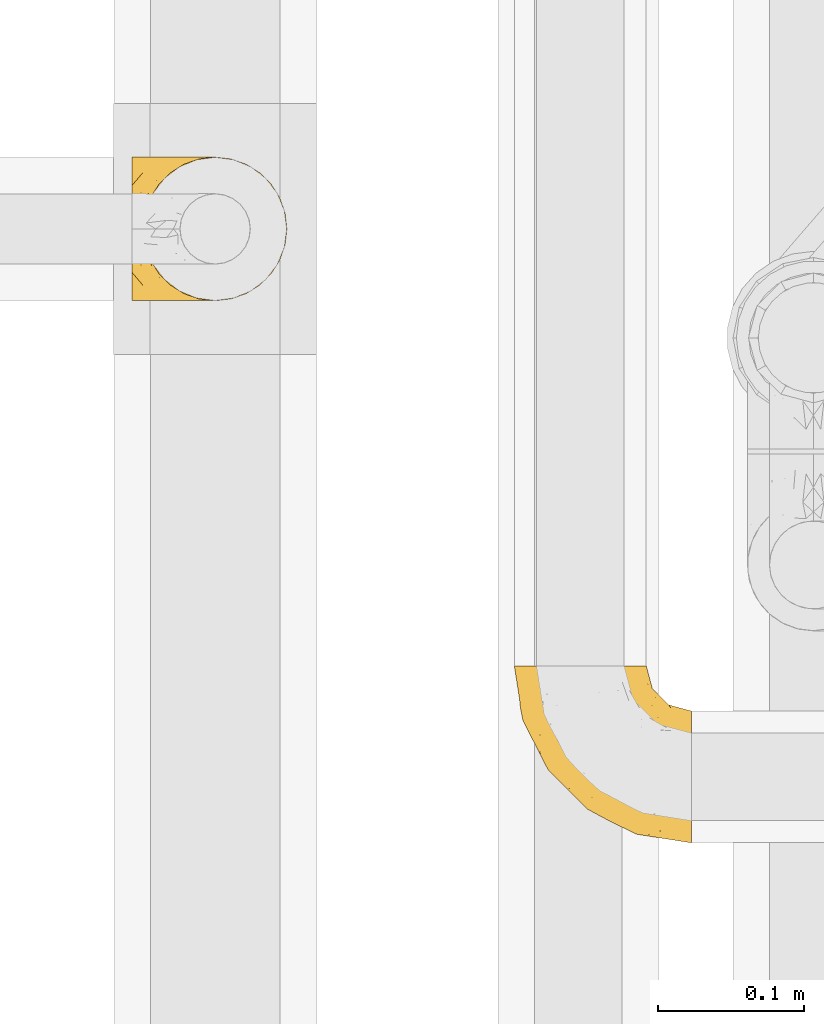
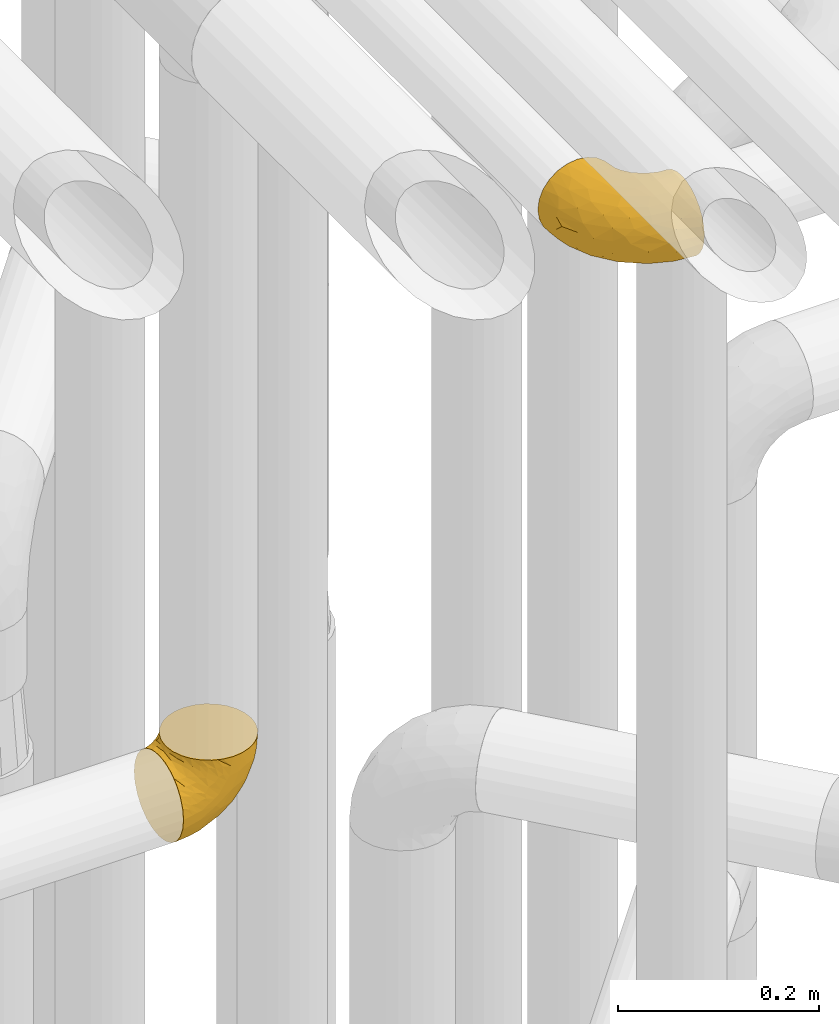
# One storey, part 192 of 827: 2 coverings.
"""IFC2X3 building model written with IfcOpenShell, lengths in millimetres."""

from ifc_helpers import new_model, entity, si_unit, converted_unit, derived_unit, direction, frame, origin, place, context, subcontext, project, spatial, faceted_brep, element, save


model = new_model("IFC2X3")

# Units and contexts
model_context = context("Model", 3, precision=0.01, world=origin(), true_north=direction((6.12303176911189e-17, 1.0)))
body_context = subcontext(model_context, "Body", "Model", "MODEL_VIEW")
ifc_project = project(units=[si_unit("LENGTHUNIT", "METRE", prefix="MILLI"), si_unit("AREAUNIT", "SQUARE_METRE"), si_unit("VOLUMEUNIT", "CUBIC_METRE"), converted_unit("PLANEANGLEUNIT", "DEGREE", entity("IfcRatioMeasure", 0.0174532925199433), si_unit("PLANEANGLEUNIT", "RADIAN"), dimensions=[0, 0, 0, 0, 0, 0, 0]), si_unit("MASSUNIT", "GRAM", prefix="KILO"), derived_unit("MASSDENSITYUNIT", [(si_unit("MASSUNIT", "GRAM", prefix="KILO"), 1), (si_unit("LENGTHUNIT", "METRE"), -3)]), derived_unit("MOMENTOFINERTIAUNIT", [(si_unit("LENGTHUNIT", "METRE"), 4)]), si_unit("TIMEUNIT", "SECOND"), si_unit("FREQUENCYUNIT", "HERTZ"), si_unit("THERMODYNAMICTEMPERATUREUNIT", "DEGREE_CELSIUS"), derived_unit("THERMALTRANSMITTANCEUNIT", [(si_unit("MASSUNIT", "GRAM", prefix="KILO"), 1), (si_unit("THERMODYNAMICTEMPERATUREUNIT", "KELVIN"), -1), (si_unit("TIMEUNIT", "SECOND"), -3)]), derived_unit("VOLUMETRICFLOWRATEUNIT", [(si_unit("LENGTHUNIT", "METRE"), 3), (si_unit("TIMEUNIT", "SECOND"), -1)]), derived_unit("MASSFLOWRATEUNIT", [(si_unit("MASSUNIT", "GRAM", prefix="KILO"), 1), (si_unit("TIMEUNIT", "SECOND"), -1)]), derived_unit("ROTATIONALFREQUENCYUNIT", [(si_unit("TIMEUNIT", "SECOND"), -1)]), si_unit("ELECTRICCURRENTUNIT", "AMPERE"), si_unit("ELECTRICVOLTAGEUNIT", "VOLT"), si_unit("POWERUNIT", "WATT"), si_unit("FORCEUNIT", "NEWTON", prefix="KILO"), si_unit("ILLUMINANCEUNIT", "LUX"), si_unit("LUMINOUSFLUXUNIT", "LUMEN"), si_unit("LUMINOUSINTENSITYUNIT", "CANDELA"), derived_unit("USERDEFINED", [(si_unit("MASSUNIT", "GRAM", prefix="KILO"), -1), (si_unit("LENGTHUNIT", "METRE"), -2), (si_unit("TIMEUNIT", "SECOND"), 3), (si_unit("LUMINOUSFLUXUNIT", "LUMEN"), 1)]), derived_unit("LINEARVELOCITYUNIT", [(si_unit("LENGTHUNIT", "METRE"), 1), (si_unit("TIMEUNIT", "SECOND"), -1)]), si_unit("PRESSUREUNIT", "PASCAL"), derived_unit("USERDEFINED", [(si_unit("LENGTHUNIT", "METRE"), -2), (si_unit("MASSUNIT", "GRAM", prefix="KILO"), 1), (si_unit("TIMEUNIT", "SECOND"), -2)]), derived_unit("LINEARFORCEUNIT", [(si_unit("MASSUNIT", "GRAM", prefix="KILO"), 1), (si_unit("LENGTHUNIT", "METRE"), 1), (si_unit("TIMEUNIT", "SECOND"), -2), (si_unit("LENGTHUNIT", "METRE"), -1)]), derived_unit("PLANARFORCEUNIT", [(si_unit("MASSUNIT", "GRAM", prefix="KILO"), 1), (si_unit("LENGTHUNIT", "METRE"), 1), (si_unit("TIMEUNIT", "SECOND"), -2), (si_unit("LENGTHUNIT", "METRE"), -2)])], contexts=[model_context])

# Site, building, storey
site_placement = place(None, origin())
site = spatial("IfcSite", under=ifc_project, at=site_placement, CompositionType="ELEMENT")
building_placement = place(site_placement, origin())
building = spatial("IfcBuilding", under=site, at=building_placement, CompositionType="ELEMENT")
storey_placement = place(building_placement, frame((0.0, 0.0, 28200.0)))
storey = spatial("IfcBuildingStorey", under=building, at=storey_placement, Name="08", CompositionType="ELEMENT", Elevation=28200.0)

# Coverings
covering_1_placement = place(storey_placement, frame((36161.44, 10105.46, 2549.25)))
element("IfcCovering", 1, at=covering_1_placement, inside=storey, Name=":ADSK_", ObjectType=":ADSK_", PredefinedType="INSULATION", context=body_context, shape_type="Brep", body=[
    faceted_brep([(58.6, 1.6, 107.75), (69.54, 2.83, 107.75), (79.93, 6.47, 107.75), (89.25, 12.32, 107.75), (97.03, 20.11, 107.75), (102.88, 29.43, 107.75), (106.51, 39.81, 107.75), (107.75, 50.75, 107.75), (106.51, 61.69, 107.75), (102.87, 72.08, 107.75), (97.02, 81.4, 107.75), (89.23, 89.18, 107.75), (79.91, 95.03, 107.75), (69.53, 98.66, 107.75), (58.6, 99.9, 107.75), (52.89, 99.25, 107.75), (47.65, 98.66, 107.75), (42.46, 96.84, 107.75), (37.26, 95.02, 107.75), (27.94, 89.17, 107.75), (20.16, 81.38, 107.75), (14.31, 72.06, 107.75), (10.68, 61.68, 107.75), (9.45, 50.75, 107.75), (10.68, 39.8, 107.75), (14.32, 29.41, 107.75), (20.17, 20.09, 107.75), (27.96, 12.31, 107.75), (37.28, 6.46, 107.75), (42.47, 4.64, 107.75), (47.66, 2.83, 107.75), (52.89, 2.24, 107.75), (55.75, 1.92, 107.75), (1.6, 63.47, 98.22), (1.6, 75.32, 93.31), (1.6, 80.41, 89.4), (1.6, 85.5, 85.5), (1.6, 89.4, 80.41), (1.6, 93.31, 75.32), (1.6, 95.77, 69.39), (1.6, 98.22, 63.47), (1.6, 99.14, 56.48), (1.6, 99.52, 53.61), (1.6, 99.9, 50.75), (1.6, 98.22, 38.02), (1.6, 93.31, 26.17), (1.6, 85.5, 15.99), (1.6, 75.32, 8.18), (1.6, 63.47, 3.27), (1.6, 50.75, 1.6), (1.6, 38.02, 3.27), (1.6, 26.17, 8.18), (1.6, 15.99, 15.99), (1.6, 8.18, 26.17), (1.6, 3.27, 38.02), (1.6, 1.6, 50.75), (1.6, 2.35, 56.48), (1.6, 3.27, 63.47), (1.6, 5.73, 69.39), (1.6, 8.18, 75.32), (1.6, 12.09, 80.41), (1.6, 15.99, 85.5), (1.6, 21.08, 89.4), (1.6, 26.17, 93.31), (1.6, 38.02, 98.22), (1.6, 50.75, 99.9), (69.96, 42.18, 27.53), (59.59, 28.42, 25.32), (51.96, 37.78, 16.29), (34.4, 50.75, 6.79), (23.37, 42.85, 4.51), (13.68, 50.75, 3.51), (41.52, 24.75, 17.47), (26.26, 33.81, 7.6), (20.18, 22.57, 12.27), (72.33, 7.18, 70.89), (65.88, 2.73, 87.17), (57.55, 3.09, 67.3), (23.76, 6.92, 31.65), (46.5, 11.58, 33.58), (46.57, 5.17, 47.23), (21.17, 2.71, 43.26), (23.41, 1.6, 55.08), (17.92, 1.6, 53.99), (12.43, 1.6, 52.9), (9.72, 1.6, 52.36), (7.01, 1.6, 51.82), (26.77, 14.18, 21.5), (76.59, 5.88, 89.94), (95.55, 41.06, 60.45), (102.57, 36.25, 83.0), (92.89, 28.62, 64.79), (54.26, 1.6, 85.93), (51.17, 1.6, 81.31), (48.08, 1.6, 76.69), (44.99, 1.6, 72.06), (41.9, 1.6, 67.44), (85.16, 10.85, 88.74), (85.97, 38.35, 45.98), (59.58, 9.6, 47.13), (99.5, 26.24, 89.4), (105.83, 50.75, 95.66), (53.59, 19.31, 28.5), (67.0, 16.41, 42.81), (71.56, 24.56, 38.28), (87.47, 50.75, 45.35), (75.73, 50.75, 33.61), (92.24, 18.47, 82.57), (58.06, 1.6, 105.04), (57.52, 1.6, 102.33), (56.44, 1.6, 96.91), (55.35, 1.6, 91.42), (81.33, 14.36, 65.92), (80.35, 20.64, 53.11), (39.44, 2.32, 54.37), (102.55, 50.75, 74.94), (37.28, 1.6, 64.35), (32.65, 1.6, 61.26), (28.03, 1.6, 58.17), (63.99, 50.75, 21.87), (74.55, 33.88, 34.79), (83.62, 29.24, 48.48), (95.01, 50.75, 60.15), (49.19, 50.75, 14.33), (46.96, 2.8, 99.07), (8.77, 2.48, 60.55), (18.28, 2.7, 64.18), (11.68, 3.2, 64.36), (11.79, 32.98, 103.17), (15.69, 24.67, 101.69), (42.49, 2.95, 87.75), (47.41, 2.19, 89.38), (7.94, 17.92, 88.34), (9.27, 12.02, 82.14), (7.98, 25.73, 94.51), (13.4, 16.63, 89.64), (13.04, 25.6, 98.41), (7.36, 36.72, 99.71), (23.46, 10.66, 89.37), (30.46, 6.87, 88.21), (26.54, 11.12, 95.2), (6.76, 10.31, 79.14), (26.46, 12.84, 101.22), (20.77, 17.38, 99.41), (20.68, 9.74, 84.72), (40.26, 4.63, 97.47), (7.15, 50.75, 102.19), (9.28, 42.52, 104.02), (38.78, 3.12, 82.66), (18.27, 17.58, 95.42), (31.78, 3.97, 78.67), (12.75, 5.94, 72.69), (22.96, 2.73, 66.46), (17.55, 6.23, 75.3), (27.63, 3.45, 72.74), (15.23, 10.84, 82.93), (33.25, 7.98, 99.27), (32.43, 7.33, 93.51), (27.9, 2.39, 67.35), (7.97, 75.76, 94.51), (15.22, 90.65, 82.94), (7.93, 83.57, 88.33), (13.38, 84.85, 89.64), (13.12, 71.05, 103.62), (42.49, 98.54, 87.74), (47.4, 99.3, 89.38), (51.17, 99.9, 81.31), (40.24, 96.86, 97.47), (20.76, 84.1, 99.41), (12.43, 99.9, 52.9), (7.01, 99.9, 51.82), (4.31, 99.9, 51.28), (26.44, 88.63, 101.21), (26.52, 90.36, 95.19), (11.68, 98.29, 64.36), (12.75, 95.55, 72.69), (9.27, 89.47, 82.13), (17.55, 95.26, 75.3), (6.76, 91.18, 79.14), (33.21, 93.49, 99.28), (32.41, 94.15, 93.51), (8.77, 99.01, 60.55), (22.96, 98.76, 66.46), (18.48, 98.85, 63.96), (56.44, 99.9, 96.91), (46.95, 98.69, 99.06), (7.36, 64.78, 99.7), (17.92, 99.9, 53.99), (23.41, 99.9, 55.08), (9.85, 62.91, 103.3), (57.52, 99.9, 102.33), (56.98, 99.9, 99.62), (48.08, 99.9, 76.69), (38.78, 98.37, 82.66), (18.25, 83.9, 95.42), (44.99, 99.9, 72.06), (31.74, 97.51, 78.68), (30.45, 94.62, 88.2), (27.63, 98.04, 72.75), (20.65, 91.73, 84.74), (55.35, 99.9, 91.42), (54.26, 99.9, 85.93), (13.03, 75.87, 98.41), (23.44, 90.83, 89.37), (27.9, 99.1, 67.35), (32.65, 99.9, 61.26), (28.03, 99.9, 58.17), (37.28, 99.9, 64.35), (41.9, 99.9, 67.44), (39.74, 99.09, 54.08), (23.37, 58.64, 4.51), (26.77, 87.31, 21.5), (46.18, 89.93, 33.43), (53.54, 82.22, 28.5), (41.53, 76.74, 17.47), (59.61, 73.12, 25.36), (76.79, 95.54, 90.18), (66.11, 98.7, 86.97), (21.17, 98.79, 43.26), (51.96, 63.71, 16.29), (26.26, 67.68, 7.6), (20.18, 78.92, 12.27), (23.76, 94.57, 31.65), (92.88, 72.88, 64.79), (102.57, 65.25, 83.0), (95.54, 60.44, 60.44), (71.63, 76.94, 38.35), (74.55, 67.61, 34.8), (72.51, 94.38, 71.54), (69.96, 59.31, 27.53), (92.23, 83.03, 82.57), (85.15, 90.66, 88.74), (80.45, 80.8, 53.19), (83.65, 72.22, 48.49), (57.57, 98.39, 67.28), (63.68, 92.31, 52.32), (85.95, 63.11, 45.94), (99.49, 75.27, 89.4), (81.23, 87.15, 65.75), (47.07, 96.03, 46.73), (66.99, 85.1, 42.82)], [[[0, 1, 2, 3, 4, 5, 6, 7, 8, 9, 10, 11, 12, 13, 14, 15, 16, 17, 18, 19, 20, 21, 22, 23, 24, 25, 26, 27, 28, 29, 30, 31, 32]], [[33, 34, 35, 36, 37, 38, 39, 40, 41, 42, 43, 44, 45, 46, 47, 48, 49, 50, 51, 52, 53, 54, 55, 56, 57, 58, 59, 60, 61, 62, 63, 64, 65]], [[66, 67, 68]], [[69, 70, 71]], [[68, 72, 73]], [[73, 72, 74]], [[75, 76, 77]], [[78, 79, 80]], [[51, 50, 73]], [[81, 82, 83, 84, 85, 86, 55]], [[52, 87, 53]], [[74, 52, 51]], [[2, 1, 88]], [[89, 90, 91]], [[77, 92, 93, 94, 95, 96]], [[55, 54, 81]], [[78, 53, 87]], [[5, 90, 6]], [[88, 76, 75]], [[97, 3, 2]], [[89, 91, 98]], [[99, 80, 79]], [[90, 5, 100]], [[74, 87, 52]], [[100, 5, 4]], [[90, 101, 6]], [[79, 102, 103]], [[102, 67, 104]], [[105, 98, 106]], [[107, 4, 3]], [[76, 0, 108, 109, 110, 111, 92]], [[107, 112, 113]], [[114, 77, 96]], [[89, 115, 90]], [[114, 96, 116, 117, 118, 82]], [[75, 97, 88]], [[119, 66, 68]], [[50, 71, 70]], [[100, 91, 90]], [[99, 77, 80]], [[102, 104, 103]], [[97, 107, 3]], [[80, 81, 78]], [[107, 97, 112]], [[68, 73, 70]], [[66, 98, 120]], [[78, 81, 54]], [[114, 81, 80]], [[53, 78, 54]], [[78, 87, 79]], [[102, 87, 72]], [[79, 103, 99]], [[4, 107, 100]], [[91, 100, 107]], [[88, 97, 2]], [[112, 97, 75]], [[99, 112, 75]], [[103, 104, 113]], [[91, 121, 98]], [[89, 105, 122, 115]], [[101, 90, 115]], [[101, 7, 6]], [[88, 1, 76]], [[0, 76, 1]], [[92, 77, 76]], [[73, 74, 51]], [[87, 74, 72]], [[81, 114, 82]], [[77, 114, 80]], [[87, 102, 79]], [[67, 102, 72]], [[68, 67, 72]], [[67, 120, 104]], [[120, 121, 104]], [[104, 121, 113]], [[121, 120, 98]], [[91, 107, 113]], [[91, 113, 121]], [[103, 113, 112]], [[106, 98, 66]], [[105, 89, 98]], [[106, 66, 119]], [[67, 66, 120]], [[68, 69, 123, 119]], [[50, 49, 71]], [[50, 70, 73]], [[112, 99, 103]], [[77, 99, 75]], [[69, 68, 70]], [[29, 124, 110]], [[84, 83, 125]], [[126, 82, 118]], [[59, 58, 127]], [[25, 128, 129]], [[130, 93, 131]], [[132, 62, 133]], [[134, 135, 136]], [[137, 65, 64]], [[64, 134, 137]], [[138, 139, 140]], [[111, 110, 124, 92]], [[134, 136, 137]], [[134, 64, 63]], [[141, 61, 60]], [[125, 58, 57]], [[142, 143, 140]], [[142, 26, 143]], [[127, 83, 82]], [[28, 124, 29]], [[108, 0, 32, 31, 30, 110, 109]], [[30, 29, 110]], [[135, 144, 138]], [[28, 145, 124]], [[57, 56, 55, 86, 85, 84]], [[146, 147, 23]], [[24, 23, 147]], [[25, 143, 26]], [[95, 94, 148]], [[24, 128, 25]], [[149, 138, 143]], [[124, 145, 131]], [[127, 58, 125]], [[150, 148, 139]], [[127, 126, 151]], [[151, 59, 127]], [[152, 151, 126]], [[153, 154, 155]], [[153, 133, 141]], [[145, 28, 27]], [[142, 156, 27]], [[157, 148, 130]], [[61, 133, 62]], [[134, 132, 135]], [[147, 128, 24]], [[65, 137, 146]], [[146, 137, 147]], [[128, 137, 136]], [[137, 128, 147]], [[128, 136, 129]], [[149, 129, 136]], [[25, 129, 143]], [[158, 152, 117]], [[152, 118, 117]], [[153, 151, 152]], [[158, 116, 154]], [[144, 150, 138]], [[153, 152, 158]], [[133, 153, 155]], [[133, 155, 132]], [[60, 151, 141]], [[135, 132, 155]], [[134, 63, 132]], [[144, 135, 155]], [[135, 138, 149]], [[155, 154, 144]], [[150, 154, 96]], [[154, 150, 144]], [[148, 94, 130]], [[82, 126, 127]], [[118, 152, 126]], [[150, 96, 95]], [[139, 148, 157]], [[150, 95, 148]], [[93, 92, 131]], [[130, 145, 156]], [[130, 94, 93]], [[84, 125, 57]], [[127, 125, 83]], [[140, 139, 157]], [[150, 139, 138]], [[140, 157, 142]], [[138, 140, 143]], [[156, 142, 157]], [[27, 26, 142]], [[130, 156, 157]], [[145, 27, 156]], [[132, 63, 62]], [[124, 131, 92]], [[130, 131, 145]], [[129, 149, 143]], [[135, 149, 136]], [[141, 133, 61]], [[60, 59, 151]], [[141, 151, 153]], [[116, 96, 154]], [[153, 158, 154]], [[158, 117, 116]], [[34, 33, 159]], [[160, 161, 162]], [[22, 21, 163]], [[164, 165, 166]], [[19, 18, 167]], [[168, 21, 20]], [[42, 41, 40, 169, 170, 171, 43]], [[172, 173, 168]], [[174, 38, 175]], [[176, 177, 178]], [[179, 164, 180]], [[40, 181, 169]], [[182, 183, 175]], [[17, 184, 185]], [[65, 146, 186]], [[187, 174, 188]], [[23, 22, 189]], [[174, 39, 38]], [[15, 14, 190, 191, 184, 16]], [[181, 40, 39]], [[192, 193, 164]], [[194, 163, 168]], [[33, 186, 159]], [[180, 173, 172]], [[195, 196, 193]], [[18, 185, 167]], [[173, 180, 197]], [[198, 199, 196]], [[200, 201, 185, 184]], [[184, 17, 16]], [[18, 17, 185]], [[202, 159, 186]], [[194, 168, 203]], [[189, 163, 202]], [[204, 205, 182]], [[187, 181, 174]], [[160, 177, 176]], [[206, 183, 182]], [[206, 182, 205]], [[201, 165, 185]], [[165, 164, 167]], [[172, 179, 180]], [[202, 194, 162]], [[176, 161, 160]], [[65, 186, 33]], [[163, 189, 22]], [[175, 177, 182]], [[174, 183, 188]], [[177, 198, 204]], [[199, 160, 162]], [[198, 207, 204]], [[175, 38, 37]], [[198, 177, 160]], [[178, 177, 175]], [[176, 35, 161]], [[34, 159, 161]], [[162, 161, 159]], [[202, 162, 159]], [[199, 162, 203]], [[196, 199, 203]], [[198, 160, 199]], [[193, 197, 180]], [[208, 198, 196]], [[188, 183, 206]], [[175, 183, 174]], [[193, 192, 195]], [[195, 208, 196]], [[197, 196, 203]], [[180, 164, 193]], [[168, 163, 21]], [[166, 165, 201]], [[166, 192, 164]], [[189, 202, 186]], [[186, 146, 189]], [[23, 189, 146]], [[174, 181, 39]], [[169, 181, 187]], [[196, 197, 193]], [[173, 203, 168]], [[203, 173, 197]], [[172, 168, 20]], [[20, 19, 172]], [[179, 172, 19]], [[19, 167, 179]], [[164, 179, 167]], [[35, 176, 36]], [[35, 34, 161]], [[185, 165, 167]], [[162, 194, 203]], [[163, 194, 202]], [[176, 178, 36]], [[37, 36, 178]], [[175, 37, 178]], [[177, 204, 182]], [[207, 198, 208]], [[207, 205, 204]], [[209, 188, 206, 205, 207, 208]], [[48, 210, 71]], [[211, 212, 213]], [[214, 213, 215]], [[216, 217, 13]], [[218, 43, 171, 170, 169, 187, 188]], [[219, 220, 214]], [[47, 46, 221]], [[210, 48, 220]], [[211, 222, 212]], [[222, 45, 44]], [[221, 220, 47]], [[47, 220, 48]], [[221, 211, 214]], [[223, 224, 225]], [[211, 46, 45]], [[226, 227, 215]], [[43, 218, 44]], [[217, 216, 228]], [[219, 215, 229]], [[14, 13, 217]], [[224, 9, 8]], [[10, 230, 11]], [[11, 231, 12]], [[232, 223, 233]], [[234, 208, 195, 192, 166, 201]], [[235, 234, 228]], [[222, 44, 218]], [[106, 229, 236]], [[224, 237, 9]], [[231, 238, 228]], [[9, 237, 10]], [[115, 224, 101]], [[239, 234, 235]], [[231, 11, 230]], [[223, 230, 237]], [[224, 8, 101]], [[223, 236, 233]], [[225, 115, 122, 105]], [[216, 12, 231]], [[209, 234, 239]], [[210, 219, 69]], [[219, 214, 215]], [[229, 119, 219]], [[209, 218, 188]], [[239, 212, 222]], [[239, 222, 218]], [[45, 222, 211]], [[235, 212, 239]], [[213, 212, 240]], [[223, 237, 224]], [[230, 10, 237]], [[238, 231, 230]], [[216, 231, 228]], [[232, 230, 223]], [[235, 238, 240]], [[115, 225, 224]], [[233, 236, 227]], [[8, 7, 101]], [[234, 209, 208]], [[218, 209, 239]], [[217, 228, 234]], [[13, 12, 216]], [[234, 201, 217]], [[217, 201, 200, 184, 191, 190, 14]], [[211, 221, 46]], [[220, 221, 214]], [[71, 210, 69]], [[71, 49, 48]], [[219, 210, 220]], [[226, 215, 213]], [[211, 213, 214]], [[226, 213, 240]], [[215, 227, 229]], [[232, 240, 238]], [[233, 227, 226]], [[232, 233, 226]], [[236, 223, 225]], [[240, 232, 226]], [[232, 238, 230]], [[225, 105, 236]], [[236, 105, 106]], [[236, 229, 227]], [[123, 69, 219, 119]], [[106, 119, 229]], [[238, 235, 228]], [[212, 235, 240]]]),
])
covering_2_placement = place(storey_placement, frame((36423.29, 9734.28, 3353.25)))
element("IfcCovering", 2, at=covering_2_placement, inside=storey, Name=":ADSK_", ObjectType=":ADSK_", PredefinedType="INSULATION", context=body_context, shape_type="Brep", body=[
    faceted_brep([(122.75, 36.69, 90.76), (122.75, 27.15, 87.42), (122.75, 18.59, 82.04), (122.75, 11.44, 74.89), (122.75, 6.06, 66.33), (122.75, 2.73, 56.79), (122.75, 1.6, 46.75), (122.75, 2.73, 36.69), (122.75, 6.07, 27.15), (122.75, 11.45, 18.59), (122.75, 18.6, 11.44), (122.75, 27.16, 6.06), (122.75, 36.7, 2.73), (122.75, 46.75, 1.6), (122.75, 56.8, 2.73), (122.75, 66.34, 6.07), (122.75, 74.9, 11.45), (122.75, 82.05, 18.6), (122.75, 87.43, 27.16), (122.75, 90.76, 36.7), (122.75, 91.9, 46.75), (122.75, 90.76, 56.8), (122.75, 87.42, 66.34), (122.75, 82.04, 74.9), (122.75, 74.89, 82.05), (122.75, 66.33, 87.43), (122.75, 56.79, 90.76), (122.75, 46.75, 91.9), (90.36, 122.75, 35.06), (85.85, 122.75, 24.17), (78.67, 122.75, 14.82), (69.32, 122.75, 7.64), (58.43, 122.75, 3.13), (46.75, 122.75, 1.6), (35.06, 122.75, 3.13), (24.17, 122.75, 7.64), (14.82, 122.75, 14.82), (7.64, 122.75, 24.17), (3.13, 122.75, 35.06), (1.6, 122.75, 46.75), (3.13, 122.75, 58.43), (7.64, 122.75, 69.32), (14.82, 122.75, 78.67), (24.17, 122.75, 85.85), (35.06, 122.75, 90.36), (46.75, 122.75, 91.9), (58.43, 122.75, 90.36), (69.32, 122.75, 85.85), (78.67, 122.75, 78.67), (85.85, 122.75, 69.32), (90.36, 122.75, 58.43), (91.9, 122.75, 46.75), (51.54, 24.73, 46.75), (47.17, 29.08, 55.2), (38.13, 38.13, 46.75), (7.52, 85.31, 46.75), (5.85, 93.59, 54.53), (5.11, 100.54, 46.75), (19.2, 63.54, 59.63), (38.98, 38.98, 62.07), (35.02, 50.71, 71.86), (8.21, 93.33, 62.65), (19.28, 75.2, 71.33), (12.19, 100.46, 72.93), (101.39, 41.6, 91.2), (34.43, 80.86, 86.31), (20.95, 94.87, 80.89), (30.74, 67.96, 79.49), (72.93, 52.16, 90.68), (56.64, 52.1, 86.84), (80.81, 36.74, 87.38), (93.43, 17.11, 76.87), (100.76, 23.24, 83.73), (74.27, 29.18, 81.03), (93.66, 52.53, 91.9), (81.33, 60.77, 91.9), (69.01, 69.01, 91.9), (40.87, 100.68, 91.03), (29.38, 103.79, 87.58), (67.05, 16.37, 56.52), (85.31, 7.52, 46.75), (93.68, 7.31, 60.4), (52.53, 93.66, 91.9), (50.71, 102.83, 91.9), (48.88, 112.01, 91.9), (72.77, 18.17, 67.87), (51.21, 71.97, 90.35), (101.18, 9.83, 69.57), (100.54, 5.11, 46.75), (48.74, 45.97, 79.91), (112.01, 48.88, 91.9), (102.83, 50.71, 91.9), (73.88, 22.83, 74.99), (24.73, 51.54, 46.75), (60.77, 81.33, 91.9), (103.08, 31.74, 88.53), (54.8, 32.48, 72.65), (16.13, 68.42, 46.75), (55.92, 25.33, 62.97), (68.42, 16.13, 46.75), (104.98, 92.29, 66.2), (108.58, 94.12, 56.6), (98.21, 100.97, 59.89), (61.56, 95.91, 90.95), (60.69, 107.9, 90.22), (100.0, 87.24, 76.64), (95.88, 95.46, 71.58), (90.81, 90.41, 79.99), (84.88, 74.17, 89.54), (73.29, 83.77, 89.97), (113.4, 76.72, 81.32), (109.8, 84.44, 74.56), (102.13, 76.42, 84.15), (67.29, 90.07, 90.37), (70.34, 99.69, 87.82), (95.15, 61.74, 90.98), (105.49, 58.16, 90.96), (71.5, 112.6, 85.14), (92.87, 110.45, 58.11), (96.03, 107.32, 46.75), (81.34, 108.48, 78.39), (107.44, 66.63, 88.22), (88.36, 115.23, 66.06), (90.43, 105.79, 68.6), (114.37, 89.6, 63.78), (98.41, 69.39, 88.42), (88.73, 66.99, 90.61), (76.89, 102.31, 83.8), (86.08, 99.54, 77.98), (112.64, 55.27, 91.22), (94.21, 82.03, 83.46), (112.22, 94.71, 46.75), (107.32, 96.03, 46.75), (79.95, 94.11, 84.66), (84.51, 84.21, 86.33), (101.67, 101.67, 46.75), (94.71, 112.22, 46.75), (81.34, 108.48, 15.1), (76.89, 102.31, 9.69), (86.08, 99.54, 15.52), (79.96, 94.11, 8.83), (92.87, 110.46, 35.39), (113.41, 76.74, 12.18), (102.83, 50.71, 1.6), (105.5, 58.17, 2.53), (112.64, 55.27, 2.27), (108.58, 94.12, 36.9), (104.98, 92.3, 27.31), (98.2, 100.98, 33.62), (98.4, 69.41, 5.07), (102.13, 76.44, 9.36), (107.44, 66.65, 5.27), (88.36, 115.24, 27.43), (50.71, 102.83, 1.6), (48.88, 112.01, 1.6), (94.22, 82.05, 10.05), (100.01, 87.25, 16.87), (71.5, 112.6, 8.35), (60.69, 107.9, 3.27), (52.53, 93.66, 1.6), (95.89, 95.48, 21.94), (114.37, 89.6, 29.72), (81.33, 60.77, 1.6), (69.01, 69.01, 1.6), (84.88, 74.17, 3.96), (112.01, 48.88, 1.6), (109.8, 84.45, 18.95), (61.56, 95.91, 2.54), (67.29, 90.07, 3.12), (60.77, 81.33, 1.6), (95.14, 61.75, 2.51), (73.29, 83.77, 3.52), (84.53, 84.21, 7.17), (93.66, 52.53, 1.6), (90.82, 90.42, 13.52), (88.73, 67.0, 2.88), (70.34, 99.69, 5.67), (90.43, 105.8, 24.89), (20.95, 94.87, 12.6), (34.43, 80.86, 7.18), (30.74, 67.95, 14.0), (19.29, 75.17, 22.16), (35.07, 50.65, 21.61), (51.21, 71.97, 3.14), (56.67, 52.08, 6.65), (54.85, 32.46, 20.82), (38.98, 38.98, 31.41), (29.38, 103.79, 5.91), (40.87, 100.68, 2.46), (19.2, 63.54, 33.87), (8.21, 93.32, 30.84), (5.85, 93.59, 38.96), (12.19, 100.44, 20.56), (72.93, 52.17, 2.81), (80.83, 36.75, 6.1), (101.39, 41.61, 2.29), (93.69, 7.31, 33.08), (93.43, 17.12, 16.61), (67.04, 16.37, 36.96), (100.76, 23.26, 9.75), (72.78, 18.17, 25.61), (55.93, 25.33, 30.5), (101.18, 9.84, 23.91), (74.27, 29.19, 12.45), (73.89, 22.84, 18.49), (103.09, 31.75, 4.96), (48.78, 45.96, 13.56), (47.19, 29.07, 38.28)], [[[0, 1, 2, 3, 4, 5, 6, 7, 8, 9, 10, 11, 12, 13, 14, 15, 16, 17, 18, 19, 20, 21, 22, 23, 24, 25, 26, 27]], [[28, 29, 30, 31, 32, 33, 34, 35, 36, 37, 38, 39, 40, 41, 42, 43, 44, 45, 46, 47, 48, 49, 50, 51]], [[52, 53, 54]], [[55, 56, 57]], [[58, 59, 60]], [[61, 62, 63]], [[27, 64, 0]], [[65, 66, 67]], [[41, 40, 61]], [[68, 69, 70]], [[66, 43, 42]], [[63, 42, 41]], [[71, 72, 73]], [[72, 2, 1]], [[68, 74, 75, 76]], [[45, 44, 77]], [[43, 78, 44]], [[79, 80, 81]], [[77, 82, 83, 84, 45]], [[79, 81, 85]], [[71, 2, 72]], [[65, 86, 77]], [[4, 81, 5]], [[66, 65, 78]], [[4, 3, 87]], [[81, 88, 5]], [[63, 66, 42]], [[68, 70, 64]], [[67, 60, 89]], [[71, 3, 2]], [[64, 27, 90, 91, 74]], [[92, 71, 73]], [[40, 57, 56]], [[59, 93, 54]], [[86, 76, 94, 82]], [[1, 0, 95]], [[58, 62, 61]], [[60, 96, 89]], [[85, 81, 87]], [[56, 97, 58]], [[65, 67, 69]], [[87, 81, 4]], [[67, 89, 69]], [[61, 63, 41]], [[95, 72, 1]], [[73, 72, 70]], [[69, 73, 70]], [[73, 89, 96]], [[3, 71, 87]], [[85, 87, 71]], [[58, 61, 56]], [[59, 58, 93]], [[76, 86, 68]], [[69, 89, 73]], [[68, 86, 69]], [[65, 69, 86]], [[68, 64, 74]], [[95, 64, 70]], [[98, 79, 85]], [[79, 52, 99, 80]], [[66, 62, 67]], [[62, 58, 60]], [[62, 60, 67]], [[59, 98, 96]], [[59, 96, 60]], [[96, 85, 92]], [[88, 81, 80]], [[88, 6, 5]], [[66, 63, 62]], [[64, 95, 0]], [[72, 95, 70]], [[77, 44, 78]], [[86, 82, 77]], [[40, 39, 57]], [[96, 98, 85]], [[40, 56, 61]], [[66, 78, 43]], [[77, 78, 65]], [[79, 98, 53]], [[96, 92, 73]], [[85, 71, 92]], [[97, 56, 55]], [[97, 93, 58]], [[53, 98, 59]], [[54, 53, 59]], [[79, 53, 52]], [[100, 101, 102]], [[46, 45, 84, 83]], [[103, 104, 82]], [[82, 104, 83]], [[105, 106, 107]], [[108, 109, 76]], [[110, 111, 112]], [[103, 113, 114]], [[115, 74, 116]], [[48, 47, 117]], [[118, 102, 119]], [[49, 48, 120]], [[74, 91, 116]], [[116, 121, 115]], [[49, 122, 50]], [[123, 106, 102]], [[124, 111, 22]], [[125, 126, 115]], [[23, 22, 111]], [[24, 110, 121]], [[120, 127, 128]], [[90, 26, 129]], [[27, 26, 90]], [[121, 125, 115]], [[24, 121, 25]], [[130, 105, 107]], [[129, 25, 116]], [[21, 20, 131]], [[120, 123, 122]], [[112, 105, 130]], [[50, 118, 51]], [[21, 124, 22]], [[101, 131, 132]], [[117, 120, 48]], [[24, 23, 110]], [[127, 114, 133]], [[75, 108, 76]], [[107, 134, 130]], [[133, 114, 113]], [[129, 116, 91]], [[25, 121, 116]], [[121, 112, 125]], [[75, 74, 115]], [[101, 135, 102]], [[131, 101, 21]], [[101, 100, 124]], [[128, 127, 133]], [[119, 136, 51, 118]], [[104, 47, 46]], [[83, 104, 46]], [[117, 104, 114]], [[101, 124, 21]], [[111, 124, 100]], [[102, 118, 123]], [[133, 134, 107]], [[111, 110, 23]], [[114, 104, 103]], [[94, 76, 109]], [[121, 110, 112]], [[122, 118, 50]], [[134, 109, 108]], [[133, 107, 128]], [[112, 108, 125]], [[126, 125, 108]], [[108, 75, 126]], [[75, 115, 126]], [[109, 134, 133]], [[130, 108, 112]], [[108, 130, 134]], [[105, 112, 111]], [[111, 100, 105]], [[106, 105, 100]], [[102, 106, 100]], [[128, 106, 123]], [[90, 129, 91]], [[25, 129, 26]], [[104, 117, 47]], [[117, 114, 127]], [[82, 94, 103]], [[113, 94, 109]], [[94, 113, 103]], [[133, 113, 109]], [[106, 128, 107]], [[123, 120, 128]], [[120, 122, 49]], [[118, 122, 123]], [[135, 101, 132]], [[135, 119, 102]], [[117, 127, 120]], [[30, 29, 137]], [[138, 139, 140]], [[51, 136, 119, 141]], [[142, 17, 16]], [[143, 144, 145]], [[146, 147, 148]], [[149, 150, 151]], [[152, 29, 28]], [[33, 32, 153, 154]], [[150, 155, 156]], [[157, 31, 30]], [[153, 158, 159]], [[29, 152, 137]], [[148, 141, 119]], [[156, 160, 147]], [[148, 135, 146]], [[137, 138, 157]], [[19, 161, 146]], [[162, 163, 164]], [[14, 13, 165]], [[153, 32, 158]], [[147, 161, 166]], [[18, 17, 166]], [[167, 168, 169]], [[166, 150, 156]], [[151, 150, 142]], [[151, 170, 149]], [[151, 16, 15]], [[171, 140, 172]], [[165, 143, 145]], [[173, 170, 144]], [[142, 166, 17]], [[19, 131, 20]], [[144, 170, 151]], [[18, 161, 19]], [[173, 144, 143]], [[140, 139, 174]], [[171, 164, 163]], [[164, 172, 155]], [[151, 15, 144]], [[145, 15, 14]], [[173, 162, 170]], [[149, 175, 164]], [[19, 146, 131]], [[132, 131, 146]], [[160, 148, 147]], [[159, 158, 167]], [[135, 132, 146]], [[158, 32, 31]], [[157, 158, 31]], [[167, 158, 176]], [[166, 161, 18]], [[146, 161, 147]], [[148, 177, 141]], [[171, 168, 140]], [[171, 163, 169]], [[151, 142, 16]], [[166, 142, 150]], [[152, 141, 177]], [[51, 141, 28]], [[138, 140, 176]], [[172, 140, 174]], [[175, 149, 170]], [[164, 150, 149]], [[170, 162, 175]], [[162, 164, 175]], [[155, 172, 174]], [[171, 172, 164]], [[155, 174, 156]], [[164, 155, 150]], [[160, 156, 174]], [[147, 166, 156]], [[139, 160, 174]], [[148, 160, 177]], [[15, 145, 144]], [[165, 145, 14]], [[137, 157, 30]], [[158, 157, 176]], [[168, 167, 176]], [[169, 159, 167]], [[140, 168, 176]], [[169, 168, 171]], [[137, 177, 139]], [[160, 139, 177]], [[141, 152, 28]], [[137, 152, 177]], [[148, 119, 135]], [[157, 138, 176]], [[139, 138, 137]], [[178, 179, 180]], [[181, 180, 182]], [[179, 183, 184]], [[185, 186, 182]], [[187, 188, 179]], [[188, 33, 154, 153, 159]], [[181, 189, 190]], [[35, 34, 187]], [[191, 38, 190]], [[192, 178, 181]], [[179, 184, 180]], [[192, 190, 37]], [[37, 190, 38]], [[36, 35, 178]], [[54, 93, 186]], [[35, 187, 178]], [[193, 194, 184]], [[195, 173, 143, 165, 13]], [[195, 193, 173]], [[193, 163, 162, 173]], [[13, 12, 195]], [[8, 7, 196]], [[9, 197, 10]], [[198, 80, 99, 52]], [[196, 7, 88]], [[197, 199, 10]], [[182, 189, 181]], [[200, 198, 201]], [[200, 196, 198]], [[9, 8, 202]], [[194, 199, 203]], [[192, 37, 36]], [[80, 196, 88]], [[183, 159, 169, 163]], [[188, 34, 33]], [[202, 200, 197]], [[185, 203, 204]], [[202, 8, 196]], [[10, 199, 11]], [[12, 11, 205]], [[38, 191, 57]], [[189, 97, 191]], [[203, 199, 197]], [[205, 199, 194]], [[204, 203, 197]], [[184, 203, 206]], [[200, 202, 196]], [[197, 9, 202]], [[207, 54, 186]], [[97, 55, 191]], [[194, 203, 184]], [[183, 163, 193]], [[184, 206, 180]], [[183, 193, 184]], [[205, 195, 12]], [[193, 195, 194]], [[80, 198, 196]], [[207, 186, 201]], [[182, 180, 206]], [[181, 178, 180]], [[185, 182, 206]], [[182, 186, 189]], [[203, 185, 206]], [[185, 200, 201]], [[7, 6, 88]], [[178, 192, 36]], [[190, 192, 181]], [[199, 205, 11]], [[195, 205, 194]], [[159, 183, 188]], [[179, 188, 183]], [[57, 191, 55]], [[57, 39, 38]], [[189, 191, 190]], [[188, 187, 34]], [[178, 187, 179]], [[186, 93, 189]], [[197, 200, 204]], [[185, 204, 200]], [[189, 93, 97]], [[207, 198, 52]], [[185, 201, 186]], [[198, 207, 201]], [[54, 207, 52]]]),
])

save(model, "model.ifc")
